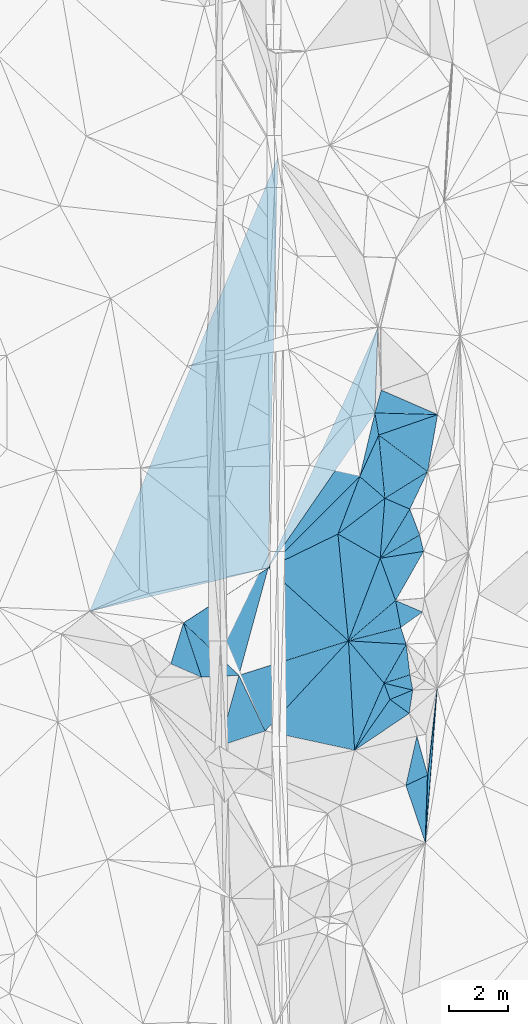
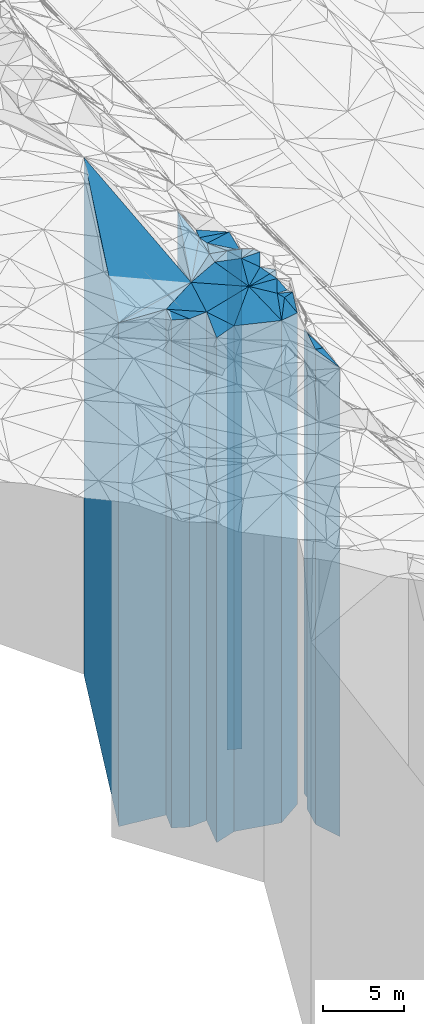
# One storey, part 199 of 275: 42 plates.
"""IFC2X3 building model written with IfcOpenShell, lengths in millimetres."""

from ifc_helpers import new_model, si_unit, frame, origin_with_axes, place, context, subcontext, project, spatial, faceted_brep, material, type_object, element, save


model = new_model("IFC2X3")

# Units and contexts
model_context = context("Model", 3, precision=1e-05, world=origin_with_axes())
body_context = subcontext(model_context, "Body", "Model", "MODEL_VIEW")
ifc_project = project(units=[si_unit("LENGTHUNIT", "METRE", prefix="MILLI"), si_unit("AREAUNIT", "SQUARE_METRE"), si_unit("VOLUMEUNIT", "CUBIC_METRE"), si_unit("MASSUNIT", "GRAM", prefix="KILO"), si_unit("TIMEUNIT", "SECOND"), si_unit("PLANEANGLEUNIT", "RADIAN"), si_unit("SOLIDANGLEUNIT", "STERADIAN"), si_unit("THERMODYNAMICTEMPERATUREUNIT", "DEGREE_CELSIUS"), si_unit("LUMINOUSINTENSITYUNIT", "LUMEN")], contexts=[model_context])

# Site, building, storey
site_placement = place(None, origin_with_axes())
site = spatial("IfcSite", under=ifc_project, at=site_placement, CompositionType="ELEMENT")
building_placement = place(site_placement, origin_with_axes())
building = spatial("IfcBuilding", under=site, at=building_placement, Name="Undefined", CompositionType="ELEMENT")
storey_placement = place(building_placement, origin_with_axes())
storey = spatial("IfcBuildingStorey", under=building, at=storey_placement, Name="Undefined", CompositionType="ELEMENT", Elevation=0.0)

# Plates
ifc_material = material()
plate_type_1 = type_object("IfcPlateType", PredefinedType="NOTDEFINED")
plate_1_placement = place(storey_placement, frame((-99153.538195565, 25183.779765965, 26809.0), z_axis=(0.312418690833504, -0.949944504493752, 0.0), x_axis=(-0.949944504493752, -0.312418690833503, 0.0)))
element("IfcPlate", 1, at=plate_1_placement, inside=storey, type_object=plate_type_1, material=ifc_material, Name="00", context=body_context, shape_type="Brep", body=[
    faceted_brep([(0.0, -18981.0, 0.0), (69.2227172851563, -19101.0, 519.334411621094), (69.2227172851563, 18981.0, 519.334411621094), (0.0, 18981.0, 0.0), (914.43969726561, -19211.0, 3.11410985887051e-09), (914.43969726561, 18981.0, 3.11410985887051e-09)], [[[0, 1, 2, 3]], [[1, 4, 5, 2]], [[4, 0, 3, 5]], [[5, 3, 2]], [[4, 1, 0]]]),
])
plate_type_2 = type_object("IfcPlateType", PredefinedType="NOTDEFINED")
plate_2_placement = place(storey_placement, frame((-100022.205181569, 24898.0917063152, 26869.0), z_axis=(0.94023991574423, 0.34051270290737, 0.0), x_axis=(0.34051270290737, -0.94023991574423, 0.0)))
element("IfcPlate", 2, at=plate_2_placement, inside=storey, type_object=plate_type_2, material=ifc_material, Name="00", context=body_context, shape_type="Brep", body=[
    faceted_brep([(-7.27595761418343e-12, -19151.0, -1.45519152283669e-11), (544.224548339844, -19041.0, 829.409240722656), (544.224548339844, 19041.0, 829.409240722656), (-7.27595761418343e-12, 19041.0, -1.45519152283669e-11), (581.377685546875, -19091.0, 1.49884726852179e-09), (581.377685546875, 19041.0, 1.49884726852179e-09)], [[[0, 1, 2, 3]], [[1, 4, 5, 2]], [[4, 0, 3, 5]], [[5, 3, 2]], [[4, 1, 0]]]),
])
plate_type_3 = type_object("IfcPlateType", PredefinedType="NOTDEFINED")
plate_3_placement = place(storey_placement, frame((-99057.0461609876, 24668.8144396924, 26349.0), z_axis=(0.382247149972043, -0.924060125932426, 0.0), x_axis=(-0.924060125932425, -0.382247149972046, 0.0)))
element("IfcPlate", 3, at=plate_3_placement, inside=storey, type_object=plate_type_3, material=ifc_material, Name="00", context=body_context, shape_type="Brep", body=[
    faceted_brep([(0.0, -19561.0, 0.0), (413.735321044922, -18521.0, 680.164001464844), (413.735321044922, 18521.0, 680.164001464844), (0.0, 18521.0, 0.0), (830.240905761719, -19611.0, -1.70257408171892e-09), (830.240905761719, 18521.0, -1.70257408171892e-09)], [[[0, 1, 2, 3]], [[1, 4, 5, 2]], [[4, 0, 3, 5]], [[5, 3, 2]], [[4, 1, 0]]]),
])
plate_type_4 = type_object("IfcPlateType", PredefinedType="NOTDEFINED")
plate_4_placement = place(storey_placement, frame((-100022.205181569, 24898.0917063152, 26924.0), z_axis=(-0.870314710874212, 0.49249599392882, 0.0), x_axis=(0.492495993928821, 0.870314710874212, 0.0)))
element("IfcPlate", 4, at=plate_4_placement, inside=storey, type_object=plate_type_4, material=ifc_material, Name="00", context=body_context, shape_type="Brep", body=[
    faceted_brep([(0.0, -19096.0, 0.0), (651.055847167976, -19166.0, 1746.60424804688), (651.055847167976, 19096.0, 1746.60424804688), (0.0, 19096.0, 0.0), (1508.01196289063, -19156.0, 6.05359673500061e-09), (1508.01196289063, 19096.0, 6.05359673500061e-09)], [[[0, 1, 2, 3]], [[1, 4, 5, 2]], [[4, 0, 3, 5]], [[5, 3, 2]], [[4, 1, 0]]]),
])
plate_type_5 = type_object("IfcPlateType", PredefinedType="NOTDEFINED")
plate_5_placement = place(storey_placement, frame((-101015.450012272, 22643.8812666528, 26754.0), z_axis=(-0.820154166614786, 0.572142589731272, 0.0), x_axis=(0.572142589731273, 0.820154166614785, 0.0)))
element("IfcPlate", 5, at=plate_5_placement, inside=storey, type_object=plate_type_5, material=ifc_material, Name="00", context=body_context, shape_type="Brep", body=[
    faceted_brep([(7.27595761418343e-12, -18926.0, 1.45519152283669e-11), (2417.07763671876, -19266.0, 475.115905761733), (2417.07763671876, 18926.0, 475.115905761733), (7.27595761418343e-12, 18926.0, 1.45519152283669e-11), (2082.01831054688, -19206.0, 4.78758011013269e-09), (2082.01831054688, 18926.0, 4.78758011013269e-09)], [[[0, 1, 2, 3]], [[1, 4, 5, 2]], [[4, 0, 3, 5]], [[5, 3, 2]], [[4, 1, 0]]]),
])
plate_type_6 = type_object("IfcPlateType", PredefinedType="NOTDEFINED")
plate_6_placement = place(storey_placement, frame((-100022.205181569, 24898.0917063152, 26754.0), z_axis=(-0.765460431398475, -0.643482966334977, 0.0), x_axis=(-0.643482966334978, 0.765460431398473, 0.0)))
element("IfcPlate", 6, at=plate_6_placement, inside=storey, type_object=plate_type_6, material=ifc_material, Name="00", context=body_context, shape_type="Brep", body=[
    faceted_brep([(0.0, -19266.0, 7.27595761418343e-12), (-1086.37280273439, -18926.0, 2210.83569335938), (-1086.37280273439, 18926.0, 2210.83569335938), (7.27595761418343e-12, 18926.0, 1.45519152283669e-11), (1864.00109863281, -19336.0, -4.74392436444759e-09), (1864.00109863281, 18926.0, -4.74392436444759e-09)], [[[0, 1, 2, 3]], [[1, 4, 5, 2]], [[4, 0, 3, 5]], [[5, 3, 2]], [[4, 1, 0]]]),
])
plate_type_7 = type_object("IfcPlateType", PredefinedType="NOTDEFINED")
plate_7_placement = place(storey_placement, frame((-99824.2386983393, 24351.4572109551, 26349.0), z_axis=(0.820154166614786, -0.572142589731272, 0.0), x_axis=(-0.572142589731274, -0.820154166614784, 0.0)))
element("IfcPlate", 7, at=plate_7_placement, inside=storey, type_object=plate_type_7, material=ifc_material, Name="00", context=body_context, shape_type="Brep", body=[
    faceted_brep([(0.0, -19611.0, 1.45519152283669e-11), (15.9460659027172, -18521.0, 797.399353027358), (15.9460659027172, 18521.0, 797.399353027358), (0.0, 18521.0, 0.0), (2082.01831054687, -19331.0, 4.78758011013269e-09), (2082.01831054687, 18521.0, 4.78758011013269e-09)], [[[0, 1, 2, 3]], [[1, 4, 5, 2]], [[4, 0, 3, 5]], [[5, 3, 2]], [[4, 1, 0]]]),
])
plate_type_8 = type_object("IfcPlateType", PredefinedType="NOTDEFINED")
plate_8_placement = place(storey_placement, frame((-99289.582390574, 21460.7578781695, 25549.0), z_axis=(-0.426848493166557, 0.904323152352874, 0.0), x_axis=(0.904323152352872, 0.426848493166561, 0.0)))
element("IfcPlate", 8, at=plate_8_placement, inside=storey, type_object=plate_type_8, material=ifc_material, Name="00", context=body_context, shape_type="Brep", body=[
    faceted_brep([(1.45519152283669e-11, -18071.0, -7.27595761418343e-12), (1043.50915527345, -18181.0, 1344.65185546874), (1043.50915527345, 17721.0, 1344.65185546874), (1.45519152283669e-11, 17721.0, 0.0), (810.24688720706, -17721.0, -2.91038304567337e-10), (810.24688720706, 17721.0, -2.91038304567337e-10)], [[[0, 1, 2, 3]], [[1, 4, 5, 2]], [[4, 0, 3, 5]], [[5, 3, 2]], [[4, 1, 0]]]),
])
plate_type_9 = type_object("IfcPlateType", PredefinedType="NOTDEFINED")
plate_9_placement = place(storey_placement, frame((-106771.214961715, 26927.1298990293, 26891.5), z_axis=(0.949718763615681, 0.313104247873295, 0.0), x_axis=(0.313104247873298, -0.94971876361568, 0.0)))
element("IfcPlate", 9, at=plate_9_placement, inside=storey, type_object=plate_type_9, material=ifc_material, Name="00", context=body_context, shape_type="Brep", body=[
    faceted_brep([(-1.45519152283669e-11, -19063.5, 0.0), (2256.76391601561, -19268.5, 1218.32067871094), (2256.76391601561, 19063.5, 1218.32067871094), (-1.45519152283669e-11, 19063.5, 0.0), (1924.20605468749, -19228.5, -2.56113708019257e-09), (1924.20605468749, 19063.5, -2.56113708019257e-09)], [[[0, 1, 2, 3]], [[1, 4, 5, 2]], [[4, 0, 3, 5]], [[5, 3, 2]], [[4, 1, 0]]]),
])
plate_type_10 = type_object("IfcPlateType", PredefinedType="NOTDEFINED")
plate_10_placement = place(storey_placement, frame((-105571.050373719, 22783.5428103199, 26859.0), z_axis=(-0.312546317051192, 0.949902521155584, 0.0), x_axis=(0.949902521155584, 0.312546317051193, 0.0)))
element("IfcPlate", 10, at=plate_10_placement, inside=storey, type_object=plate_type_10, material=ifc_material, Name="00", context=body_context, shape_type="Brep", body=[
    faceted_brep([(0.0, -19031.0, 7.27595761418343e-12), (1374.66955566406, -19301.0, 2055.06298828126), (1374.66955566406, 19031.0, 2055.06298828126), (0.0, 19031.0, 7.27595761418343e-12), (1627.88208007813, -19081.0, -3.84898157790303e-09), (1627.88208007813, 19031.0, -3.84898157790303e-09)], [[[0, 1, 2, 3]], [[1, 4, 5, 2]], [[4, 0, 3, 5]], [[5, 3, 2]], [[4, 1, 0]]]),
])
plate_type_11 = type_object("IfcPlateType", PredefinedType="NOTDEFINED")
plate_11_placement = place(storey_placement, frame((-107199.470514643, 25551.4387340557, 26891.5), z_axis=(0.401428765049996, 0.91589024811406, 0.0), x_axis=(0.915890248114062, -0.401428765049994, 0.0)))
element("IfcPlate", 11, at=plate_11_placement, inside=storey, type_object=plate_type_11, material=ifc_material, Name="00", context=body_context, shape_type="Brep", body=[
    faceted_brep([(-5.45696821063757e-12, -19228.5, 2.91038304567337e-11), (-160.006927490249, -19063.5, 1431.89624023438), (-160.006927490249, 19063.5, 1431.89624023438), (-1.45519152283669e-11, 19063.5, 0.0), (1125.3887939453, -19228.5, 3.45244188793004e-09), (1125.3887939453, 19063.5, 3.45244188793004e-09)], [[[0, 1, 2, 3]], [[1, 4, 5, 2]], [[4, 0, 3, 5]], [[5, 3, 2]], [[4, 1, 0]]]),
])
plate_type_12 = type_object("IfcPlateType", PredefinedType="NOTDEFINED")
plate_12_placement = place(storey_placement, frame((-104907.550578569, 25165.3001493106, 26843.5), z_axis=(-0.96475904334791, 0.263134924094894, 0.0), x_axis=(0.263134924094893, 0.96475904334791, 0.0)))
element("IfcPlate", 12, at=plate_12_placement, inside=storey, type_object=plate_type_12, material=ifc_material, Name="00", context=body_context, shape_type="Brep", body=[
    faceted_brep([(3.63797880709171e-12, -19316.5, 0.0), (1209.34594726563, -19111.5, 2261.5859375), (1209.34594726563, 19015.5, 2261.5859375), (3.63797880709171e-12, 19015.5, 0.0), (3741.25756835938, -19015.5, -5.82076609134674e-09), (3741.25756835938, 19015.5, -5.82076609134674e-09)], [[[0, 1, 2, 3]], [[1, 4, 5, 2]], [[4, 0, 3, 5]], [[5, 3, 2]], [[4, 1, 0]]]),
])
plate_type_13 = type_object("IfcPlateType", PredefinedType="NOTDEFINED")
plate_13_placement = place(storey_placement, frame((-98556.8573815155, 21806.6105362484, 25489.0), z_axis=(0.426848493166557, -0.904323152352874, 0.0), x_axis=(-0.904323152352875, -0.426848493166555, 0.0)))
element("IfcPlate", 13, at=plate_13_placement, inside=storey, type_object=plate_type_13, material=ifc_material, Name="00", context=body_context, shape_type="Brep", body=[
    faceted_brep([(-2.91038304567337e-11, -17781.0, 1.45519152283669e-11), (1041.37402343747, -17661.0, 2027.91284179688), (1041.37402343747, 17661.0, 2027.91284179688), (-2.91038304567337e-11, 17661.0, 1.45519152283669e-11), (810.246887207017, -18131.0, -2.7648638933897e-10), (810.246887207017, 17661.0, -2.7648638933897e-10)], [[[0, 1, 2, 3]], [[1, 4, 5, 2]], [[4, 0, 3, 5]], [[5, 3, 2]], [[4, 1, 0]]]),
])
plate_type_14 = type_object("IfcPlateType", PredefinedType="NOTDEFINED")
plate_14_placement = place(storey_placement, frame((-104907.550578569, 25165.3001493106, 26843.5), z_axis=(-0.300106227930336, 0.953905787778555, 0.0), x_axis=(0.953905787778556, 0.300106227930332, 0.0)))
element("IfcPlate", 14, at=plate_14_placement, inside=storey, type_object=plate_type_14, material=ifc_material, Name="00", context=body_context, shape_type="Brep", body=[
    faceted_brep([(3.63797880709171e-12, -19316.5, 0.0), (2022.28491210939, -19015.5, 3147.59790039063), (2022.28491210939, 19015.5, 3147.59790039063), (3.63797880709171e-12, 19015.5, 0.0), (3864.00048828124, -19246.5, 2.40688677877188e-08), (3864.00048828124, 19015.5, 2.40688677877188e-08)], [[[0, 1, 2, 3]], [[1, 4, 5, 2]], [[4, 0, 3, 5]], [[5, 3, 2]], [[4, 1, 0]]]),
])
plate_type_15 = type_object("IfcPlateType", PredefinedType="NOTDEFINED")
plate_15_placement = place(storey_placement, frame((-98556.8573815155, 21806.6105362484, 25337.0), z_axis=(0.999442267688168, -0.0333939149895815, 0.0), x_axis=(-0.0333939149895795, -0.999442267688169, 0.0)))
element("IfcPlate", 15, at=plate_15_placement, inside=storey, type_object=plate_type_15, material=ifc_material, Name="00", context=body_context, shape_type="Brep", body=[
    faceted_brep([(0.0, -17933.0, 1.45519152283669e-11), (-2908.55541992188, -17509.0, 221.654556274429), (-2908.55541992188, 17509.0, 221.654556274429), (-7.27595761418343e-12, 17509.0, -1.45519152283669e-11), (2279.6689453125, -17813.0, 2.00816430151463e-09), (2279.6689453125, 17509.0, 2.00816430151463e-09)], [[[0, 1, 2, 3]], [[1, 4, 5, 2]], [[4, 0, 3, 5]], [[5, 3, 2]], [[4, 1, 0]]]),
])
plate_type_16 = type_object("IfcPlateType", PredefinedType="NOTDEFINED")
plate_16_placement = place(storey_placement, frame((-101015.450012272, 22643.8812666528, 26754.0), z_axis=(-0.998434611284573, -0.055931449015941, 0.0), x_axis=(-0.05593144901594, 0.998434611284574, 0.0)))
element("IfcPlate", 16, at=plate_16_placement, inside=storey, type_object=plate_type_16, material=ifc_material, Name="00", context=body_context, shape_type="Brep", body=[
    faceted_brep([(7.27595761418343e-12, -18926.0, 1.45519152283669e-11), (815.747924804691, -19186.0, 2968.29174804689), (815.747924804691, 18926.0, 2968.29174804689), (7.27595761418343e-12, 18926.0, 1.45519152283669e-11), (3686.80078125, -19336.0, 8.00355337560177e-10), (3686.80078125, 18926.0, 8.00355337560177e-10)], [[[0, 1, 2, 3]], [[1, 4, 5, 2]], [[4, 0, 3, 5]], [[5, 3, 2]], [[4, 1, 0]]]),
])
plate_type_17 = type_object("IfcPlateType", PredefinedType="NOTDEFINED")
plate_17_placement = place(storey_placement, frame((-99996.1329798822, 31120.0946185854, 26134.0), z_axis=(-0.529673576326626, 0.848201569523048, 0.0), x_axis=(0.848201569523047, 0.529673576326627, 0.0)))
element("IfcPlate", 17, at=plate_17_placement, inside=storey, type_object=plate_type_17, material=ifc_material, Name="00", context=body_context, shape_type="Brep", body=[
    faceted_brep([(0.0, -19306.0, 0.0), (950.351501464829, -18666.0, 1914.84521484375), (950.351501464829, 18306.0, 1914.84521484375), (0.0, 18306.0, 0.0), (1697.05627441406, -18306.0, -1.11904228106141e-08), (1697.05627441406, 18306.0, -1.11904228106141e-08)], [[[0, 1, 2, 3]], [[1, 4, 5, 2]], [[4, 0, 3, 5]], [[5, 3, 2]], [[4, 1, 0]]]),
])
plate_type_18 = type_object("IfcPlateType", PredefinedType="NOTDEFINED")
plate_18_placement = place(storey_placement, frame((-98224.058566093, 33937.3543283022, 26179.0), z_axis=(-0.0256918599919177, -0.99966990968527, 0.0), x_axis=(-0.99966990968527, 0.0256918599919117, 0.0)))
element("IfcPlate", 18, at=plate_18_placement, inside=storey, type_object=plate_type_18, material=ifc_material, Name="00", context=body_context, shape_type="Brep", body=[
    faceted_brep([(-1.45519152283669e-11, -18351.0, -3.63797880709171e-12), (1961.85412597653, -18621.0, 740.356994628906), (1961.85412597653, 18351.0, 740.356994628906), (0.0, 18351.0, -1.45519152283669e-11), (2108.65844726563, -18629.0, 2.91038304567337e-09), (2108.65844726563, 18351.0, 2.91038304567337e-09)], [[[0, 1, 2, 3]], [[1, 4, 5, 2]], [[4, 0, 3, 5]], [[5, 3, 2]], [[4, 1, 0]]]),
])
plate_type_19 = type_object("IfcPlateType", PredefinedType="NOTDEFINED")
plate_19_placement = place(storey_placement, frame((-98224.058566093, 33937.3543283022, 26134.0), z_axis=(0.328917992112006, -0.944358488321573, 0.0), x_axis=(-0.944358488321573, -0.328917992112006, 0.0)))
element("IfcPlate", 19, at=plate_19_placement, inside=storey, type_object=plate_type_19, material=ifc_material, Name="00", context=body_context, shape_type="Brep", body=[
    faceted_brep([(1.45519152283669e-11, -18396.0, -1.45519152283669e-11), (945.108337402344, -18306.0, 1702.22509765625), (945.108337402344, 18306.0, 1702.22509765625), (0.0, 18306.0, 0.0), (2096.90258789064, -18666.0, 8.10541678220034e-09), (2096.90258789064, 18306.0, 8.10541678220034e-09)], [[[0, 1, 2, 3]], [[1, 4, 5, 2]], [[4, 0, 3, 5]], [[5, 3, 2]], [[4, 1, 0]]]),
])
plate_type_20 = type_object("IfcPlateType", PredefinedType="NOTDEFINED")
plate_20_placement = place(storey_placement, frame((-100119.158317883, 34761.3670289126, 26179.0), z_axis=(0.963834018138489, -0.266503256038298, 0.0), x_axis=(-0.266503256038286, -0.963834018138493, 0.0)))
element("IfcPlate", 20, at=plate_20_placement, inside=storey, type_object=plate_type_20, material=ifc_material, Name="00", context=body_context, shape_type="Brep", body=[
    faceted_brep([(0.0, -18671.0, 0.0), (289.161224365209, -18351.0, 2046.16369628905), (289.161224365209, 18351.0, 2046.16369628905), (0.0, 18351.0, -1.45519152283669e-11), (798.723999023438, -18629.0, -4.36557456851006e-10), (798.723999023438, 18351.0, -4.36557456851006e-10)], [[[0, 1, 2, 3]], [[1, 4, 5, 2]], [[4, 0, 3, 5]], [[5, 3, 2]], [[4, 1, 0]]]),
])
plate_type_21 = type_object("IfcPlateType", PredefinedType="NOTDEFINED")
plate_21_placement = place(storey_placement, frame((-98556.6871840692, 32018.9804850425, 26134.0), z_axis=(0.529673576326626, -0.848201569523048, 0.0), x_axis=(-0.848201569523047, -0.529673576326627, 0.0)))
element("IfcPlate", 21, at=plate_21_placement, inside=storey, type_object=plate_type_21, material=ifc_material, Name="00", context=body_context, shape_type="Brep", body=[
    faceted_brep([(1.45519152283669e-11, -18306.0, -1.45519152283669e-11), (1178.0399169922, -19356.0, 750.947387695298), (1178.0399169922, 18306.0, 750.947387695298), (0.0, 18306.0, 0.0), (1697.05627441408, -19306.0, -1.12049747258425e-08), (1697.05627441406, 18306.0, -1.11904228106141e-08)], [[[0, 1, 2, 3]], [[1, 4, 5, 2]], [[4, 0, 3, 5]], [[5, 3, 2]], [[4, 1, 0]]]),
])
plate_type_22 = type_object("IfcPlateType", PredefinedType="NOTDEFINED")
plate_22_placement = place(storey_placement, frame((-100204.286220213, 33247.6453767437, 26314.0), z_axis=(0.909753672372084, -0.415148474169792, 0.0), x_axis=(-0.415148474169792, -0.909753672372084, 0.0)))
element("IfcPlate", 22, at=plate_22_placement, inside=storey, type_object=plate_type_22, material=ifc_material, Name="00", context=body_context, shape_type="Brep", body=[
    faceted_brep([(5.45696821063757e-12, -18486.0, 0.0), (1849.13256835938, -19126.0, 1072.61767578124), (1849.13256835938, 18486.0, 1072.61767578124), (5.45696821063757e-12, 18486.0, 0.0), (1534.26525878907, -18756.0, 8.26548784971237e-09), (1534.26525878907, 18486.0, 8.26548784971237e-09)], [[[0, 1, 2, 3]], [[1, 4, 5, 2]], [[4, 0, 3, 5]], [[5, 3, 2]], [[4, 1, 0]]]),
])
plate_type_23 = type_object("IfcPlateType", PredefinedType="NOTDEFINED")
plate_23_placement = place(storey_placement, frame((-100204.286220213, 33247.6453767437, 26314.0), z_axis=(-0.985575525813329, -0.169236174967944, 0.0), x_axis=(-0.169236174967949, 0.985575525813328, 0.0)))
element("IfcPlate", 23, at=plate_23_placement, inside=storey, type_object=plate_type_23, material=ifc_material, Name="00", context=body_context, shape_type="Brep", body=[
    faceted_brep([(5.45696821063757e-12, -18486.0, 0.0), (-1267.87512207031, -18756.0, 863.98071289064), (-1267.87512207031, 18486.0, 863.98071289064), (5.45696821063757e-12, 18486.0, 0.0), (754.771484375, -18494.0, 1.60071067512035e-09), (754.771484375, 18486.0, 1.60071067512035e-09)], [[[0, 1, 2, 3]], [[1, 4, 5, 2]], [[4, 0, 3, 5]], [[5, 3, 2]], [[4, 1, 0]]]),
])
plate_type_24 = type_object("IfcPlateType", PredefinedType="NOTDEFINED")
plate_24_placement = place(storey_placement, frame((-99158.1454780888, 30758.0491147629, 26634.0), z_axis=(-0.396608911052253, -0.917987675120939, 0.0), x_axis=(-0.917987675120938, 0.396608911052253, 0.0)))
element("IfcPlate", 24, at=plate_24_placement, inside=storey, type_object=plate_type_24, material=ifc_material, Name="00", context=body_context, shape_type="Brep", body=[
    faceted_brep([(0.0, -18856.0, 0.0), (258.420684814482, -19516.0, 1913.56176757813), (258.420684814482, 18806.0, 1913.56176757813), (0.0, 18806.0, 0.0), (912.852661132827, -18806.0, -5.23505150340497e-09), (912.852661132827, 18806.0, -5.23505150340497e-09)], [[[0, 1, 2, 3]], [[1, 4, 5, 2]], [[4, 0, 3, 5]], [[5, 3, 2]], [[4, 1, 0]]]),
])
plate_type_25 = type_object("IfcPlateType", PredefinedType="NOTDEFINED")
plate_25_placement = place(storey_placement, frame((-100154.308129895, 29103.9149088575, 26859.0), z_axis=(-0.155947811020461, 0.987765296129565, 0.0), x_axis=(0.987765296129565, 0.155947811020456, 0.0)))
element("IfcPlate", 25, at=plate_25_placement, inside=storey, type_object=plate_type_25, material=ifc_material, Name="00", context=body_context, shape_type="Brep", body=[
    faceted_brep([(0.0, -19291.0, 0.0), (1432.45434570314, -19031.0, 566.899108886719), (1432.45434570314, 19031.0, 566.899108886719), (0.0, 19031.0, 7.27595761418343e-12), (1479.62829589844, -19131.0, 7.78527464717627e-09), (1479.62829589844, 19031.0, 7.78527464717627e-09)], [[[0, 1, 2, 3]], [[1, 4, 5, 2]], [[4, 0, 3, 5]], [[5, 3, 2]], [[4, 1, 0]]]),
])
plate_type_26 = type_object("IfcPlateType", PredefinedType="NOTDEFINED")
plate_26_placement = place(storey_placement, frame((-101575.257563197, 29918.9012326685, 26634.0), z_axis=(0.497525913127901, 0.867449114222989, 0.0), x_axis=(0.867449114222992, -0.497525913127896, 0.0)))
element("IfcPlate", 26, at=plate_26_placement, inside=storey, type_object=plate_type_26, material=ifc_material, Name="00", context=body_context, shape_type="Brep", body=[
    faceted_brep([(-1.45519152283669e-11, -19236.0, 0.0), (772.185363769531, -18806.0, 1827.62951660157), (772.185363769531, 18806.0, 1827.62951660157), (0.0, 18806.0, 0.0), (1638.078125, -19516.0, -4.38376446254551e-09), (1638.078125, 18806.0, -4.38376446254551e-09)], [[[0, 1, 2, 3]], [[1, 4, 5, 2]], [[4, 0, 3, 5]], [[5, 3, 2]], [[4, 1, 0]]]),
])
plate_type_27 = type_object("IfcPlateType", PredefinedType="NOTDEFINED")
plate_27_placement = place(storey_placement, frame((-101221.658121529, 26324.9107715164, 26849.0), z_axis=(-0.93351407476569, 0.358540753910009, 0.0), x_axis=(0.358540753910006, 0.933514074765691, 0.0)))
element("IfcPlate", 27, at=plate_27_placement, inside=storey, type_object=plate_type_27, material=ifc_material, Name="00", context=body_context, shape_type="Brep", body=[
    faceted_brep([(-1.81898940354586e-12, -19241.0, 1.45519152283669e-11), (3228.26098632812, -19021.0, 1618.68212890626), (3228.26098632812, 19021.0, 1618.68212890626), (-1.81898940354586e-12, 19021.0, 1.45519152283669e-11), (2976.92797851563, -19301.0, 7.88713805377483e-09), (2976.92797851563, 19021.0, 7.88713805377483e-09)], [[[0, 1, 2, 3]], [[1, 4, 5, 2]], [[4, 0, 3, 5]], [[5, 3, 2]], [[4, 1, 0]]]),
])
plate_type_28 = type_object("IfcPlateType", PredefinedType="NOTDEFINED")
plate_28_placement = place(storey_placement, frame((-99996.1329798822, 31120.0946185854, 26449.0), z_axis=(-0.654586304022868, -0.755987282026412, 0.0), x_axis=(-0.755987282026408, 0.654586304022872, 0.0)))
element("IfcPlate", 28, at=plate_28_placement, inside=storey, type_object=plate_type_28, material=ifc_material, Name="00", context=body_context, shape_type="Brep", body=[
    faceted_brep([(0.0, -18991.0, -7.27595761418343e-12), (407.513366699219, -19421.0, 1941.76025390624), (407.513366699219, 18621.0, 1941.76025390624), (0.0, 18621.0, -7.27595761418343e-12), (1117.87744140625, -18621.0, 3.43425199389458e-09), (1117.87744140625, 18621.0, 3.43425199389458e-09)], [[[0, 1, 2, 3]], [[1, 4, 5, 2]], [[4, 0, 3, 5]], [[5, 3, 2]], [[4, 1, 0]]]),
])
plate_type_29 = type_object("IfcPlateType", PredefinedType="NOTDEFINED")
plate_29_placement = place(storey_placement, frame((-101221.658121529, 26324.9107715164, 26959.0), z_axis=(-0.650145120649434, 0.759810056590286, 0.0), x_axis=(0.759810056590287, 0.650145120649432, 0.0)))
element("IfcPlate", 29, at=plate_29_placement, inside=storey, type_object=plate_type_29, material=ifc_material, Name="00", context=body_context, shape_type="Brep", body=[
    faceted_brep([(-2.18278728425503e-11, -19131.0, 1.45519152283669e-11), (2617.73925781249, -19191.0, 1417.58288574219), (2617.73925781249, 19131.0, 1417.58288574219), (-2.18278728425503e-11, 19131.0, 1.45519152283669e-11), (2088.06127929685, -19221.0, -1.11613189801574e-08), (2088.06127929685, 19131.0, -1.11613189801574e-08)], [[[0, 1, 2, 3]], [[1, 4, 5, 2]], [[4, 0, 3, 5]], [[5, 3, 2]], [[4, 1, 0]]]),
])
plate_type_30 = type_object("IfcPlateType", PredefinedType="NOTDEFINED")
plate_30_placement = place(storey_placement, frame((-98692.7826126044, 29334.6597079497, 26909.0), z_axis=(0.155947811020461, -0.987765296129565, 0.0), x_axis=(-0.987765296129565, -0.155947811020456, 0.0)))
element("IfcPlate", 30, at=plate_30_placement, inside=storey, type_object=plate_type_30, material=ifc_material, Name="00", context=body_context, shape_type="Brep", body=[
    faceted_brep([(1.45519152283669e-11, -19081.0, 0.0), (1188.47412109378, -19271.0, 1485.03503417968), (1188.47412109378, 19081.0, 1485.03503417968), (1.45519152283669e-11, 19081.0, 0.0), (1479.62829589845, -19241.0, 7.77799868956208e-09), (1479.62829589845, 19081.0, 7.77799868956208e-09)], [[[0, 1, 2, 3]], [[1, 4, 5, 2]], [[4, 0, 3, 5]], [[5, 3, 2]], [[4, 1, 0]]]),
])
plate_type_31 = type_object("IfcPlateType", PredefinedType="NOTDEFINED")
plate_31_placement = place(storey_placement, frame((-101221.658121529, 26324.9107715164, 26959.0), z_axis=(-0.247659886909292, 0.968847036645144, 0.0), x_axis=(0.968847036645144, 0.247659886909292, 0.0)))
element("IfcPlate", 31, at=plate_31_placement, inside=storey, type_object=plate_type_31, material=ifc_material, Name="00", context=body_context, shape_type="Brep", body=[
    faceted_brep([(-2.18278728425503e-11, -19131.0, 1.45519152283669e-11), (1873.31372070313, -19221.0, 922.33154296875), (1873.31372070313, 19131.0, 922.33154296875), (-2.18278728425503e-11, 19131.0, 1.45519152283669e-11), (1814.96557617186, -19201.0, -9.3496055342257e-09), (1814.96557617186, 19131.0, -9.3496055342257e-09)], [[[0, 1, 2, 3]], [[1, 4, 5, 2]], [[4, 0, 3, 5]], [[5, 3, 2]], [[4, 1, 0]]]),
])
plate_type_32 = type_object("IfcPlateType", PredefinedType="NOTDEFINED")
plate_32_placement = place(storey_placement, frame((-99463.2341129198, 26774.4049382711, 26954.0), z_axis=(0.247659886909292, -0.968847036645144, 0.0), x_axis=(-0.968847036645144, -0.247659886909292, 0.0)))
element("IfcPlate", 32, at=plate_32_placement, inside=storey, type_object=plate_type_32, material=ifc_material, Name="00", context=body_context, shape_type="Brep", body=[
    faceted_brep([(0.0, -19206.0, 0.0), (-38.3478355407715, -19126.0, 591.801879882805), (-38.3478355407715, 19126.0, 591.801879882805), (0.0, 19126.0, 0.0), (1814.96557617188, -19136.0, -9.36415744945407e-09), (1814.96557617188, 19126.0, -9.36415744945407e-09)], [[[0, 1, 2, 3]], [[1, 4, 5, 2]], [[4, 0, 3, 5]], [[5, 3, 2]], [[4, 1, 0]]]),
])
plate_type_33 = type_object("IfcPlateType", PredefinedType="NOTDEFINED")
plate_33_placement = place(storey_placement, frame((-99635.1281454736, 27682.4536382715, 26864.0), z_axis=(0.982550271693918, 0.185997213942059, 0.0), x_axis=(0.185997213942061, -0.982550271693918, 0.0)))
element("IfcPlate", 33, at=plate_33_placement, inside=storey, type_object=plate_type_33, material=ifc_material, Name="00", context=body_context, shape_type="Brep", body=[
    faceted_brep([(0.0, -19316.0, -1.45519152283669e-11), (548.921813964836, -19036.0, 816.078918457017), (548.921813964836, 19036.0, 816.078918457017), (7.27595761418343e-12, 19036.0, 1.45519152283669e-11), (924.17529296875, -19296.0, 2.47382558882236e-10), (924.17529296875, 19036.0, 2.47382558882236e-10)], [[[0, 1, 2, 3]], [[1, 4, 5, 2]], [[4, 0, 3, 5]], [[5, 3, 2]], [[4, 1, 0]]]),
])
plate_type_34 = type_object("IfcPlateType", PredefinedType="NOTDEFINED")
plate_34_placement = place(storey_placement, frame((-99279.5153443607, 26210.5366787644, 26809.0), z_axis=(0.870314710874212, -0.49249599392882, 0.0), x_axis=(-0.492495993928821, -0.870314710874212, 0.0)))
element("IfcPlate", 34, at=plate_34_placement, inside=storey, type_object=plate_type_34, material=ifc_material, Name="00", context=body_context, shape_type="Brep", body=[
    faceted_brep([(0.0, -19271.0, 0.0), (831.558410644531, -18981.0, 615.313415527344), (831.558410644531, 18981.0, 615.313415527344), (0.0, 18981.0, 0.0), (1508.01196289063, -19211.0, 6.03904481977224e-09), (1508.01196289063, 18981.0, 6.03904481977224e-09)], [[[0, 1, 2, 3]], [[1, 4, 5, 2]], [[4, 0, 3, 5]], [[5, 3, 2]], [[4, 1, 0]]]),
])
plate_type_35 = type_object("IfcPlateType", PredefinedType="NOTDEFINED")
plate_35_placement = place(storey_placement, frame((-101575.257563197, 29918.9012326685, 26449.0), z_axis=(-0.934862892388364, 0.355008975147478, 0.0), x_axis=(0.355008975147477, 0.934862892388364, 0.0)))
element("IfcPlate", 35, at=plate_35_placement, inside=storey, type_object=plate_type_35, material=ifc_material, Name="00", context=body_context, shape_type="Brep", body=[
    faceted_brep([(3.63797880709171e-12, -19421.0, 0.0), (-1903.1630859375, -19410.0, 1788.70874023439), (-1903.1630859375, 18621.0, 1788.70874023439), (0.0, 18621.0, -7.27595761418343e-12), (2067.61938476563, -18621.0, 1.26601662486792e-09), (2067.61938476563, 18621.0, 1.26601662486792e-09)], [[[0, 1, 2, 3]], [[1, 4, 5, 2]], [[4, 0, 3, 5]], [[5, 3, 2]], [[4, 1, 0]]]),
])
plate_type_36 = type_object("IfcPlateType", PredefinedType="NOTDEFINED")
plate_36_placement = place(storey_placement, frame((-103923.095024849, 28774.71232621, 26318.0), z_axis=(-0.823709175241405, 0.567012517166177, 0.0), x_axis=(0.567012517166176, 0.823709175241406, 0.0)))
element("IfcPlate", 36, at=plate_36_placement, inside=storey, type_object=plate_type_36, material=ifc_material, Name="00", context=body_context, shape_type="Brep", body=[
    faceted_brep([(-7.27595761418343e-12, -19541.0, 0.0), (8768.26660156251, -18740.0, 1550.99572753905), (8768.26660156251, 18490.0, 1550.99572753905), (0.0, 18490.0, 1.45519152283669e-11), (6333.32421875001, -18490.0, 1.41008058562875e-08), (6333.32421875001, 18490.0, 1.41008058562875e-08)], [[[0, 1, 2, 3]], [[1, 4, 5, 2]], [[4, 0, 3, 5]], [[5, 3, 2]], [[4, 1, 0]]]),
])
plate_type_37 = type_object("IfcPlateType", PredefinedType="NOTDEFINED")
plate_37_placement = place(storey_placement, frame((-103923.095024849, 28774.71232621, 26318.0), z_axis=(-0.706563372042762, 0.707649773042825, 0.0), x_axis=(0.707649773042826, 0.706563372042761, 0.0)))
element("IfcPlate", 37, at=plate_37_placement, inside=storey, type_object=plate_type_37, material=ifc_material, Name="00", context=body_context, shape_type="Brep", body=[
    faceted_brep([(-7.27595761418343e-12, -19541.0, 0.0), (6227.23486328126, -18490.0, 1154.35815429688), (6227.23486328126, 18490.0, 1154.35815429688), (0.0, 18490.0, 1.45519152283669e-11), (4355.0654296875, -18752.0, -1.76951289176941e-08), (4355.0654296875, 18490.0, -1.76951289176941e-08)], [[[0, 1, 2, 3]], [[1, 4, 5, 2]], [[4, 0, 3, 5]], [[5, 3, 2]], [[4, 1, 0]]]),
])
plate_type_38 = type_object("IfcPlateType", PredefinedType="NOTDEFINED")
plate_38_placement = place(storey_placement, frame((-103596.002192829, 42599.8797494003, 26809.0), z_axis=(0.92379217741766, -0.382894258173114, 0.0), x_axis=(-0.382894258173112, -0.923792177417661, 0.0)))
element("IfcPlate", 38, at=plate_38_placement, inside=storey, type_object=plate_type_38, material=ifc_material, Name="00", context=body_context, shape_type="Brep", body=[
    faceted_brep([(0.0, -19987.0, 0.0), (12896.8232421875, -19050.0, 4991.41162109374), (12896.8232421875, 18981.0, 4991.41162109374), (0.0, 18981.0, 0.0), (16546.76171875, -18981.0, 1.92667357623577e-08), (16546.76171875, 18981.0, 1.92667357623577e-08)], [[[0, 1, 2, 3]], [[1, 4, 5, 2]], [[4, 0, 3, 5]], [[5, 3, 2]], [[4, 1, 0]]]),
])
plate_type_39 = type_object("IfcPlateType", PredefinedType="NOTDEFINED")
plate_39_placement = place(storey_placement, frame((-109931.661978282, 27314.1113656064, 26809.0), z_axis=(0.121537463013398, 0.992586845109418, 0.0), x_axis=(0.992586845109418, -0.121537463013398, 0.0)))
element("IfcPlate", 39, at=plate_39_placement, inside=storey, type_object=plate_type_39, material=ifc_material, Name="00", context=body_context, shape_type="Brep", body=[
    faceted_brep([(0.0, -18981.0, 0.0), (5786.50683593747, -19050.0, 2180.03930664062), (5786.50683593747, 18981.0, 2180.03930664062), (0.0, 18981.0, 0.0), (3184.05078124997, -19146.0, 3.68163455277681e-09), (3184.05078124997, 18981.0, 3.68163455277681e-09)], [[[0, 1, 2, 3]], [[1, 4, 5, 2]], [[4, 0, 3, 5]], [[5, 3, 2]], [[4, 1, 0]]]),
])
plate_type_40 = type_object("IfcPlateType", PredefinedType="NOTDEFINED")
plate_40_placement = place(storey_placement, frame((-101575.257563197, 29918.9012326685, 26843.5), z_axis=(0.43808411392834, -0.89893398485296, 0.0), x_axis=(-0.898933984852959, -0.438084113928342, 0.0)))
element("IfcPlate", 40, at=plate_40_placement, inside=storey, type_object=plate_type_40, material=ifc_material, Name="00", context=body_context, shape_type="Brep", body=[
    faceted_brep([(0.0, -19026.5, 0.0), (1256.6075439453, -19246.5, 3385.66650390625), (1256.6075439453, 19015.5, 3385.66650390625), (3.63797880709171e-12, 19015.5, 0.0), (2611.8017578125, -19015.5, 5.83531800657511e-09), (2611.8017578125, 19015.5, 5.83531800657511e-09)], [[[0, 1, 2, 3]], [[1, 4, 5, 2]], [[4, 0, 3, 5]], [[5, 3, 2]], [[4, 1, 0]]]),
])
plate_type_41 = type_object("IfcPlateType", PredefinedType="NOTDEFINED")
plate_41_placement = place(storey_placement, frame((-100154.308129895, 29103.9149088575, 26659.0), z_axis=(-0.508487522915286, 0.861069357856541, 0.0), x_axis=(0.861069357856539, 0.508487522915289, 0.0)))
element("IfcPlate", 41, at=plate_41_placement, inside=storey, type_object=plate_type_41, material=ifc_material, Name="00", context=body_context, shape_type="Brep", body=[
    faceted_brep([(0.0, -19491.0, 1.45519152283669e-11), (1698.87170410156, -18831.0, 917.788024902358), (1698.87170410156, 18831.0, 917.788024902358), (0.0, 18831.0, 1.45519152283669e-11), (1540.55187988281, -19231.0, -3.09955794364214e-09), (1540.55187988281, 18831.0, -3.09955794364214e-09)], [[[0, 1, 2, 3]], [[1, 4, 5, 2]], [[4, 0, 3, 5]], [[5, 3, 2]], [[4, 1, 0]]]),
])
plate_type_42 = type_object("IfcPlateType", PredefinedType="NOTDEFINED")
plate_42_placement = place(storey_placement, frame((-104907.550578569, 25165.3001493106, 26884.0), z_axis=(0.904552004542773, 0.426363308784482, 0.0), x_axis=(0.426363308784481, -0.904552004542773, 0.0)))
element("IfcPlate", 42, at=plate_42_placement, inside=storey, type_object=plate_type_42, material=ifc_material, Name="00", context=body_context, shape_type="Brep", body=[
    faceted_brep([(0.0, -19276.0, 0.0), (522.601196289063, -19206.0, 3828.49682617188), (522.601196289063, 19056.0, 3828.49682617188), (-1.45519152283669e-11, 19056.0, -1.45519152283669e-11), (2070.60375976561, -19056.0, 2.03726813197136e-09), (2070.60375976561, 19056.0, 2.03726813197136e-09)], [[[0, 1, 2, 3]], [[1, 4, 5, 2]], [[4, 0, 3, 5]], [[5, 3, 2]], [[4, 1, 0]]]),
])

save(model, "model.ifc")
